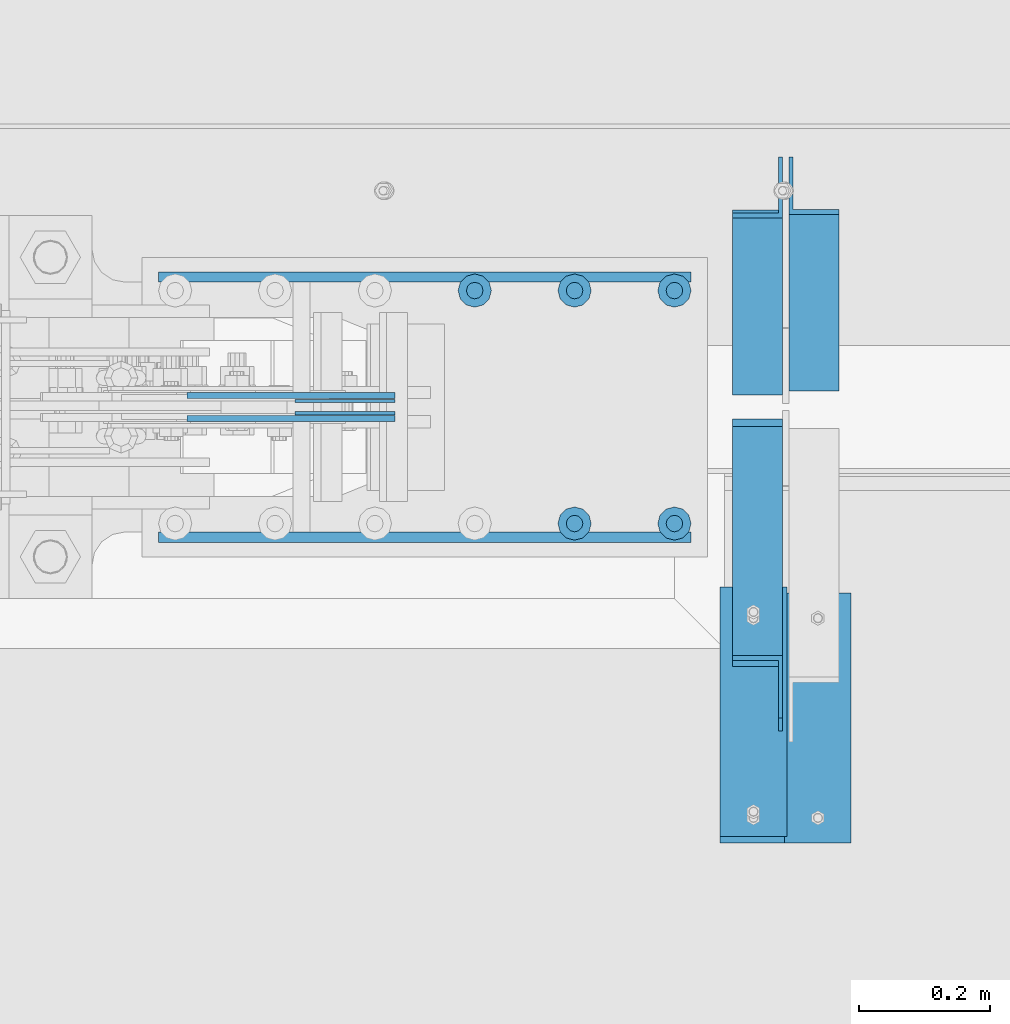
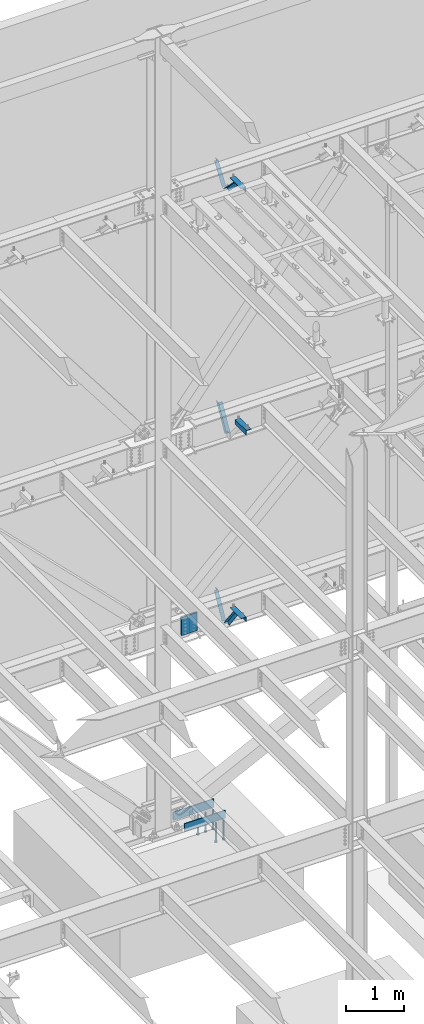
# One storey, part 889 of 1179: 14 beams, 5 members, 14 elements without a shape of their own.
"""IFC2X3 building model written with IfcOpenShell, lengths in millimetres."""

from ifc_helpers import new_model, si_unit, frame, origin_with_axes, place, context, subcontext, project, spatial, faceted_brep, material, type_object, element, aggregate, save


model = new_model("IFC2X3")

# Units and contexts
model_context = context("Model", 3, precision=1e-05, world=origin_with_axes())
body_context = subcontext(model_context, "Body", "Model", "MODEL_VIEW")
ifc_project = project(units=[si_unit("LENGTHUNIT", "METRE", prefix="MILLI"), si_unit("AREAUNIT", "SQUARE_METRE"), si_unit("VOLUMEUNIT", "CUBIC_METRE"), si_unit("MASSUNIT", "GRAM", prefix="KILO"), si_unit("TIMEUNIT", "SECOND"), si_unit("PLANEANGLEUNIT", "RADIAN"), si_unit("SOLIDANGLEUNIT", "STERADIAN"), si_unit("THERMODYNAMICTEMPERATUREUNIT", "DEGREE_CELSIUS"), si_unit("LUMINOUSINTENSITYUNIT", "LUMEN")], contexts=[model_context])

# Site, building, storey
site_placement = place(None, origin_with_axes())
site = spatial("IfcSite", under=ifc_project, at=site_placement, CompositionType="ELEMENT")
building_placement = place(site_placement, origin_with_axes())
building = spatial("IfcBuilding", under=site, at=building_placement, Name="Undefined", CompositionType="ELEMENT")
storey_placement = place(building_placement, origin_with_axes())
storey = spatial("IfcBuildingStorey", under=building, at=storey_placement, Name="Undefined", CompositionType="ELEMENT", Elevation=0.0)

# Assembly, member
assembly_1_placement = place(storey_placement, origin_with_axes())
assembly_1 = element("IfcElementAssembly", 1, at=assembly_1_placement, inside=storey, Name="ANGLE", AssemblyPlace="NOTDEFINED", PredefinedType="RIGID_FRAME")
ifc_material_1 = material(Name="STEEL/A36")
member_type = type_object("IfcMemberType", Name="L3X3X1/4", PredefinedType="NOTDEFINED")
member_1_placement = place(assembly_1_placement, frame((9674.225, 41656.0, 8227.31342088179), z_axis=(0.0, 0.872675718014636, -0.488300206008189), x_axis=(0.0, -0.48830020600819, -0.872675718014636)))
member_1 = element("IfcMember", 2, at=member_1_placement, type_object=member_type, material=ifc_material_1, Name="ANGLE", ObjectType="L3X3X1/4", context=body_context, shape_type="Brep", body=[
    faceted_brep([(266.09845322503, 38.1000000000004, -38.1000000001477), (223.461222774196, 38.1000000000004, 38.0999999997293), (818.212094408347, 38.1000000000004, 38.0999999992346), (818.21209440822, 38.1000000000004, -38.100000000617), (223.461222774196, 31.75, 38.0999999997293), (818.212094408347, 31.75, 38.0999999992346), (262.545350687458, 31.75, -31.7500000001601), (818.212094408227, 31.75, -31.7500000006257), (262.545350687458, -38.1000000000004, -31.7500000001601), (818.212094408227, -38.1000000000004, -31.7500000006257), (266.09845322503, -38.1000000000004, -38.1000000001477), (818.21209440822, -38.1000000000004, -38.100000000617)], [[[0, 1, 2, 3]], [[1, 4, 5, 2]], [[4, 6, 7, 5]], [[6, 8, 9, 7]], [[8, 10, 11, 9]], [[10, 0, 3, 11]], [[5, 7, 9, 11, 3, 2]], [[10, 8, 6, 4, 1, 0]]]),
])
aggregate(assembly_1, [member_1])

assembly_2_placement = place(storey_placement, origin_with_axes())
assembly_2 = element("IfcElementAssembly", 3, at=assembly_2_placement, inside=storey, Name="ANGLE", AssemblyPlace="NOTDEFINED", PredefinedType="RIGID_FRAME")
member_2_placement = place(assembly_2_placement, frame((9588.50025, 41256.8364339201, 3601.33927004389), z_axis=(0.0, 0.873306509536275, -0.487171161299155), x_axis=(0.0, 0.487171161299156, 0.873306509536275)))
member_2 = element("IfcMember", 4, at=member_2_placement, type_object=member_type, material=ifc_material_1, Name="ANGLE", ObjectType="L3X3X1/4", context=body_context, shape_type="Brep", body=[
    faceted_brep([(0.0, 38.0999999999985, -38.0999999999999), (0.0, 38.0999999999985, 38.0999999999999), (594.661720177039, 38.1000000000004, 38.1000000011991), (552.153801037723, 38.1000000000004, -38.0999999989144), (0.0, 31.75, 38.1000000000004), (594.661720177039, 31.75, 38.1000000011991), (0.0, 31.75, -31.75), (555.696127632669, 31.75, -31.7499999988941), (0.0, -38.0999999999985, -31.75), (555.696127632669, -38.1000000000004, -31.7499999988941), (0.0, -38.0999999999985, -38.0999999999999), (552.153801037723, -38.1000000000004, -38.0999999989144)], [[[0, 1, 2, 3]], [[1, 4, 5, 2]], [[4, 6, 7, 5]], [[6, 8, 9, 7]], [[8, 10, 11, 9]], [[10, 0, 3, 11]], [[5, 7, 9, 11, 3, 2]], [[10, 8, 6, 4, 1, 0]]]),
])
aggregate(assembly_2, [member_2])

assembly_3_placement = place(storey_placement, origin_with_axes())
assembly_3 = element("IfcElementAssembly", 5, at=assembly_3_placement, inside=storey, Name="ANGLE", AssemblyPlace="NOTDEFINED", PredefinedType="RIGID_FRAME")
member_3_placement = place(assembly_3_placement, frame((9588.49975000001, 40722.5024246856, 4156.39103856133), z_axis=(0.0, -0.797785167426298, -0.602941810322185), x_axis=(0.0, 0.602941810322187, -0.797785167426297)))
member_3 = element("IfcMember", 6, at=member_3_placement, type_object=member_type, material=ifc_material_1, Name="ANGLE", ObjectType="L3X3X1/4", context=body_context, shape_type="Brep", body=[
    faceted_brep([(110.776215380578, 38.1000000000004, -38.1000000000058), (53.1865686658894, 38.1000000000004, 38.1000000001659), (690.351875241478, 38.1000000000004, 38.1000000007261), (690.351875241598, 38.1000000000004, -38.0999999994892), (53.1865686658894, 31.75, 38.1000000001659), (690.351875241478, 31.75, 38.1000000007261), (105.977078154352, 31.75, -31.7499999999927), (690.351875241595, 31.75, -31.7499999994689), (105.977078154352, -38.1000000000004, -31.7499999999927), (690.351875241595, -38.1000000000004, -31.7499999994689), (110.776215380578, -38.1000000000004, -38.1000000000058), (690.351875241598, -38.1000000000004, -38.0999999994892)], [[[0, 1, 2, 3]], [[1, 4, 5, 2]], [[4, 6, 7, 5]], [[6, 8, 9, 7]], [[8, 10, 11, 9]], [[10, 0, 3, 11]], [[5, 7, 9, 11, 3, 2]], [[10, 8, 6, 4, 1, 0]]]),
])
aggregate(assembly_3, [member_3])

assembly_4_placement = place(storey_placement, origin_with_axes())
assembly_4 = element("IfcElementAssembly", 7, at=assembly_4_placement, inside=storey, Name="ANGLE", AssemblyPlace="NOTDEFINED", PredefinedType="RIGID_FRAME")
member_4_placement = place(assembly_4_placement, frame((9588.50000000001, 40704.7386537875, 13150.1502196524), z_axis=(0.0, -0.706388288025418, -0.707824545025474), x_axis=(0.0, 0.707824545025473, -0.706388288025419)))
member_4 = element("IfcMember", 8, at=member_4_placement, type_object=member_type, material=ifc_material_1, Name="ANGLE", ObjectType="L3X3X1/4", context=body_context, shape_type="Brep", body=[
    faceted_brep([(634.184990526992, 31.75, 38.0999999999767), (634.184990526996, 31.75, -31.7499999999636), (634.184990526996, -38.0999999999985, -31.7499999999636), (634.184990526996, -38.0999999999985, -38.0999999999549), (634.184990526996, 38.0999999999985, -38.0999999999549), (634.184990526992, 38.0999999999985, 38.0999999999767), (113.596638248473, -38.0999999999985, -38.0999999999549), (113.596638248473, 38.0999999999985, -38.0999999999549), (37.2417053522113, 38.0999999999985, 38.0999999999694), (37.2417053522113, 31.75, 38.0999999999694), (107.233727173789, 31.75, -31.7499999999709), (107.233727173789, -38.0999999999985, -31.7499999999709)], [[[0, 1, 2, 3, 4, 5]], [[4, 3, 6, 7]], [[5, 4, 7, 8]], [[0, 5, 8, 9]], [[1, 0, 9, 10]], [[2, 1, 10, 11]], [[3, 2, 11, 6]], [[10, 9, 8, 7, 6, 11]]]),
])
aggregate(assembly_4, [member_4])

assembly_5_placement = place(storey_placement, origin_with_axes())
assembly_5 = element("IfcElementAssembly", 9, at=assembly_5_placement, inside=storey, Name="ANGLE", AssemblyPlace="NOTDEFINED", PredefinedType="RIGID_FRAME")
member_5_placement = place(assembly_5_placement, frame((9588.5, 41248.3636551321, 12707.4244380128), z_axis=(0.0, 0.821716663099518, -0.569896241069015), x_axis=(0.0, 0.569896241069016, 0.821716663099518)))
member_5 = element("IfcMember", 10, at=member_5_placement, type_object=member_type, material=ifc_material_1, Name="ANGLE", ObjectType="L3X3X1/4", context=body_context, shape_type="Brep", body=[
    faceted_brep([(0.0, -38.0999999999985, -38.0999999999999), (0.0, -38.0999999999985, -31.75), (0.0, 31.75, -31.75), (0.0, 31.75, 38.1000000000004), (0.0, 38.0999999999985, 38.0999999999999), (0.0, 38.0999999999985, -38.0999999999999), (527.418547333735, 31.75, 38.0999999993364), (527.418547333735, 38.1000000000004, 38.0999999993364), (474.570533511644, 38.1000000000004, -38.1000000006607), (474.570533511644, -38.1000000000004, -38.1000000006607), (478.974534663488, -38.1000000000004, -31.7500000006621), (478.974534663488, 31.75, -31.7500000006621)], [[[0, 1, 2, 3, 4, 5]], [[4, 3, 6, 7]], [[5, 4, 7, 8]], [[0, 5, 8, 9]], [[1, 0, 9, 10]], [[2, 1, 10, 11]], [[3, 2, 11, 6]], [[10, 9, 8, 7, 6, 11]]]),
])
aggregate(assembly_5, [member_5])

# Assembly, beams
assembly_6_placement = place(storey_placement, origin_with_axes())
assembly_6 = element("IfcElementAssembly", 11, at=assembly_6_placement, inside=storey, Name="BEAM", AssemblyPlace="NOTDEFINED", PredefinedType="RIGID_FRAME")
ifc_material_2 = material(Name="STEEL/A572-GR.50")
beam_type_1 = type_object("IfcBeamType", PredefinedType="NOTDEFINED")
beam_1_placement = place(assembly_6_placement, frame((8882.58952609227, 41189.27475, 3827.46249389647), z_axis=(0.0, 0.0, 1.0), x_axis=(1.0, 0.0, 0.0)))
beam_1 = element("IfcBeam", 12, at=beam_1_placement, type_object=beam_type_1, material=ifc_material_2, Name="PLATE", context=body_context, shape_type="Brep", body=[
    faceted_brep([(0.0, 2.38150000000314, -190.5), (0.0, 2.38150000000314, 190.5), (152.399999999998, 2.38150000000314, 190.5), (152.399999999998, 2.38150000000314, -190.5), (0.0, -2.38150000000314, 190.5), (152.399999999998, -2.38150000000314, 190.5), (0.0, -2.38150000000314, -190.5), (152.399999999998, -2.38150000000314, -190.5)], [[[0, 1, 2, 3]], [[1, 4, 5, 2]], [[4, 6, 7, 5]], [[6, 0, 3, 7]], [[5, 7, 3, 2]], [[6, 4, 1, 0]]]),
])
beam_2_placement = place(assembly_6_placement, frame((8882.58952609227, 41208.32525, 3827.46249389647), z_axis=(0.0, 0.0, 1.0), x_axis=(1.0, 0.0, 0.0)))
beam_2 = element("IfcBeam", 13, at=beam_2_placement, type_object=beam_type_1, material=ifc_material_2, Name="PLATE", context=body_context, shape_type="Brep", body=[
    faceted_brep([(0.0, 2.38150000000314, -190.5), (0.0, 2.38150000000314, 190.5), (152.399999999998, 2.38150000000314, 190.5), (152.399999999998, 2.38150000000314, -190.5), (0.0, -2.38150000000314, 190.5), (152.399999999998, -2.38150000000314, 190.5), (0.0, -2.38150000000314, -190.5), (152.399999999998, -2.38150000000314, -190.5)], [[[0, 1, 2, 3]], [[1, 4, 5, 2]], [[4, 6, 7, 5]], [[6, 0, 3, 7]], [[5, 7, 3, 2]], [[6, 4, 1, 0]]]),
])
aggregate(assembly_6, [beam_1, beam_2])

# Assembly, beam
assembly_7_placement = place(storey_placement, origin_with_axes())
assembly_7 = element("IfcElementAssembly", 14, at=assembly_7_placement, inside=storey, Name="ANGLE", AssemblyPlace="NOTDEFINED", PredefinedType="RIGID_FRAME")
beam_type_2 = type_object("IfcBeamType", Name="L4X4X1/4", PredefinedType="NOTDEFINED")
beam_3_placement = place(assembly_7_placement, frame((9680.575, 40533.6375, 7962.9), z_axis=(1.0, 0.0, 0.0), x_axis=(0.0, 1.0, 0.0)))
beam_3 = element("IfcBeam", 15, at=beam_3_placement, type_object=beam_type_2, material=ifc_material_1, Name="ANGLE", ObjectType="L4X4X1/4", context=body_context, shape_type="Brep", body=[
    faceted_brep([(1.90993887372315e-11, 50.8000000000002, -50.8000000000002), (1.90993887372315e-11, 50.8000000000002, 50.8000000000002), (381.0, 50.8000000000002, 50.7999999999993), (381.0, 50.8000000000002, -50.7999999999993), (0.0, 44.4500000000007, 50.8000000000002), (381.0, 44.4499999999998, 50.7999999999993), (0.0, 44.4500000000007, -44.4499999999998), (381.0, 44.4499999999998, -44.4500000000007), (0.0, -50.7999999999993, -44.4499999999998), (381.0, -50.8000000000002, -44.4500000000007), (-1.81898940354586e-11, -50.7999999999997, -50.8000000000002), (381.0, -50.8000000000002, -50.7999999999993)], [[[0, 1, 2, 3]], [[1, 4, 5, 2]], [[4, 6, 7, 5]], [[6, 8, 9, 7]], [[8, 10, 11, 9]], [[10, 0, 3, 11]], [[5, 7, 9, 11, 3, 2]], [[10, 8, 6, 4, 1, 0]]]),
])
aggregate(assembly_7, [beam_3])

assembly_8_placement = place(storey_placement, origin_with_axes())
assembly_8 = element("IfcElementAssembly", 16, at=assembly_8_placement, inside=storey, Name="ANGLE", AssemblyPlace="NOTDEFINED", PredefinedType="RIGID_FRAME")
beam_4_placement = place(assembly_8_placement, frame((9582.15024999845, 40914.6373750007, 4051.30000000071), z_axis=(-1.0, 0.0, 0.0), x_axis=(0.0, -1.0, 0.0)))
beam_4 = element("IfcBeam", 17, at=beam_4_placement, type_object=beam_type_2, material=ifc_material_1, Name="ANGLE", ObjectType="L4X4X1/4", context=body_context, shape_type="Brep", body=[
    faceted_brep([(1.90993887372315e-11, 50.8000000000002, -50.8000000000002), (1.90993887372315e-11, 50.8000000000002, 50.8000000000002), (381.0, 50.8000000000002, 50.7999999999993), (381.0, 50.8000000000002, -50.7999999999993), (0.0, 44.4500000000007, 50.8000000000002), (381.0, 44.4499999999998, 50.7999999999993), (0.0, 44.4500000000007, -44.4499999999998), (381.0, 44.4499999999998, -44.4500000000007), (0.0, -50.7999999999993, -44.4499999999998), (381.0, -50.8000000000002, -44.4500000000007), (-1.81898940354586e-11, -50.7999999999997, -50.8000000000002), (381.0, -50.8000000000002, -50.7999999999993)], [[[0, 1, 2, 3]], [[1, 4, 5, 2]], [[4, 6, 7, 5]], [[6, 8, 9, 7]], [[8, 10, 11, 9]], [[10, 0, 3, 11]], [[5, 7, 9, 11, 3, 2]], [[10, 8, 6, 4, 1, 0]]]),
])
aggregate(assembly_8, [beam_4])

assembly_9_placement = place(storey_placement, origin_with_axes())
assembly_9 = element("IfcElementAssembly", 18, at=assembly_9_placement, inside=storey, Name="ANGLE", AssemblyPlace="NOTDEFINED", PredefinedType="RIGID_FRAME")
beam_5_placement = place(assembly_9_placement, frame((9582.14999999795, 40924.1624999531, 13068.3), z_axis=(-1.0, 0.0, 0.0), x_axis=(0.0, -1.0, 0.0)))
beam_5 = element("IfcBeam", 19, at=beam_5_placement, type_object=beam_type_2, material=ifc_material_1, Name="ANGLE", ObjectType="L4X4X1/4", context=body_context, shape_type="Brep", body=[
    faceted_brep([(1.90993887372315e-11, 50.8000000000002, -50.8000000000002), (1.90993887372315e-11, 50.8000000000002, 50.8000000000002), (381.0, 50.8000000000002, 50.7999999999993), (381.0, 50.8000000000002, -50.7999999999993), (0.0, 44.4500000000007, 50.8000000000002), (381.0, 44.4499999999998, 50.7999999999993), (0.0, 44.4500000000007, -44.4499999999998), (381.0, 44.4499999999998, -44.4500000000007), (0.0, -50.7999999999993, -44.4499999999998), (381.0, -50.8000000000002, -44.4500000000007), (-1.81898940354586e-11, -50.7999999999997, -50.8000000000002), (381.0, -50.8000000000002, -50.7999999999993)], [[[0, 1, 2, 3]], [[1, 4, 5, 2]], [[4, 6, 7, 5]], [[6, 8, 9, 7]], [[8, 10, 11, 9]], [[10, 0, 3, 11]], [[5, 7, 9, 11, 3, 2]], [[10, 8, 6, 4, 1, 0]]]),
])
aggregate(assembly_9, [beam_5])

assembly_10_placement = place(storey_placement, origin_with_axes())
assembly_10 = element("IfcElementAssembly", 20, at=assembly_10_placement, inside=storey, Name="PLATE", AssemblyPlace="NOTDEFINED", PredefinedType="RIGID_FRAME")
beam_type_3 = type_object("IfcBeamType", PredefinedType="NOTDEFINED")
beam_6_placement = place(assembly_10_placement, frame((9034.98952609227, 41181.3375, 3827.46249389647), z_axis=(0.0, 0.0, -1.0), x_axis=(-1.0, 0.0, 0.0)))
beam_6 = element("IfcBeam", 21, at=beam_6_placement, type_object=beam_type_3, material=ifc_material_2, Name="PLATE", context=body_context, shape_type="Brep", body=[
    faceted_brep([(0.0, 4.76249999999709, -190.5), (0.0, 4.76249999999709, 190.5), (317.499999999995, 4.76250000000073, 190.500000000051), (317.500000000042, 4.76250000000073, -190.499999999973), (0.0, -4.76249999999709, 190.5), (317.499999999995, -4.76250000000073, 190.500000000051), (0.0, -4.76249999999709, -190.5), (317.500000000042, -4.76250000000073, -190.499999999973)], [[[0, 1, 2, 3]], [[1, 4, 5, 2]], [[4, 6, 7, 5]], [[6, 0, 3, 7]], [[5, 7, 3, 2]], [[6, 4, 1, 0]]]),
])
aggregate(assembly_10, [beam_6])

assembly_11_placement = place(storey_placement, origin_with_axes())
assembly_11 = element("IfcElementAssembly", 22, at=assembly_11_placement, inside=storey, Name="PLATE", AssemblyPlace="NOTDEFINED", PredefinedType="RIGID_FRAME")
beam_7_placement = place(assembly_11_placement, frame((8717.48952609227, 41216.2625, 3827.46249389647), z_axis=(0.0, 0.0, -1.0), x_axis=(1.0, 0.0, 0.0)))
beam_7 = element("IfcBeam", 23, at=beam_7_placement, type_object=beam_type_3, material=ifc_material_2, Name="PLATE", context=body_context, shape_type="Brep", body=[
    faceted_brep([(0.0, 4.76249999999709, -190.5), (0.0, 4.76249999999709, 190.5), (317.499999999995, 4.76250000000073, 190.500000000051), (317.500000000042, 4.76250000000073, -190.499999999973), (0.0, -4.76249999999709, 190.5), (317.499999999995, -4.76250000000073, 190.500000000051), (0.0, -4.76249999999709, -190.5), (317.500000000042, -4.76250000000073, -190.499999999973)], [[[0, 1, 2, 3]], [[1, 4, 5, 2]], [[4, 6, 7, 5]], [[6, 0, 3, 7]], [[5, 7, 3, 2]], [[6, 4, 1, 0]]]),
])
aggregate(assembly_11, [beam_7])

assembly_12_placement = place(storey_placement, origin_with_axes())
assembly_12 = element("IfcElementAssembly", 24, at=assembly_12_placement, inside=storey, Name="PLATE", AssemblyPlace="NOTDEFINED", PredefinedType="RIGID_FRAME")
beam_type_4 = type_object("IfcBeamType", PredefinedType="NOTDEFINED")
beam_8_placement = place(assembly_12_placement, frame((8674.1, 41397.2375015263, -266.7), z_axis=(0.0, 0.0, 1.0), x_axis=(1.0, 0.0, 0.0)))
beam_8 = element("IfcBeam", 25, at=beam_8_placement, type_object=beam_type_4, material=ifc_material_2, Name="PLATE", context=body_context, shape_type="Brep", body=[
    faceted_brep([(0.0, -7.9375, -88.9), (0.0, 7.9375, -73.025), (812.799999999999, 7.9375, -73.025), (812.799999999999, -7.9375, -88.9), (0.0, 7.9375, 88.9), (812.799999999999, 7.9375, 88.9), (0.0, -7.9375, 88.9), (812.799999999999, -7.9375, 88.9)], [[[0, 1, 2, 3]], [[4, 5, 2, 1]], [[4, 6, 7, 5]], [[6, 0, 3, 7]], [[5, 7, 3, 2]], [[6, 4, 1, 0]]]),
])
aggregate(assembly_12, [beam_8])

assembly_13_placement = place(storey_placement, origin_with_axes())
assembly_13 = element("IfcElementAssembly", 26, at=assembly_13_placement, inside=storey, Name="PLATE", AssemblyPlace="NOTDEFINED", PredefinedType="RIGID_FRAME")
beam_9_placement = place(assembly_13_placement, frame((8674.1, 41000.3624984737, -266.7), z_axis=(0.0, 0.0, 1.0), x_axis=(1.0, 0.0, 0.0)))
beam_9 = element("IfcBeam", 27, at=beam_9_placement, type_object=beam_type_4, material=ifc_material_2, Name="PLATE", context=body_context, shape_type="Brep", body=[
    faceted_brep([(812.799999999999, 7.9375, -88.9), (812.799999999999, -7.9375, -73.025), (0.0, -7.9375, -73.025), (0.0, 7.9375, -88.9), (0.0, 7.9375, 88.9), (812.799999999999, 7.9375, 88.9), (0.0, -7.9375, 88.9), (812.799999999999, -7.9375, 88.9)], [[[0, 1, 2, 3]], [[3, 4, 5, 0]], [[4, 6, 7, 5]], [[7, 6, 2, 1]], [[5, 7, 1, 0]], [[6, 4, 3, 2]]]),
])
aggregate(assembly_13, [beam_9])

# Assembly, beams
assembly_14_placement = place(storey_placement, origin_with_axes())
assembly_14 = element("IfcElementAssembly", 28, at=assembly_14_placement, inside=storey, Name="EMBED_PLATE", AssemblyPlace="NOTDEFINED", PredefinedType="RIGID_FRAME")
ifc_material_3 = material(Name="STEEL/A108")
beam_type_5 = type_object("IfcBeamType", Name="STUD_1-DIA", PredefinedType="NOTDEFINED")
beam_10_placement = place(assembly_14_placement, frame((9461.5, 41376.6, -393.7), z_axis=(1.0, 0.0, 0.0), x_axis=(0.0, 0.0, -1.0)))
beam_10 = element("IfcBeam", 29, at=beam_10_placement, type_object=beam_type_5, material=ifc_material_3, Name="STUD", ObjectType="STUD_1-DIA", context=body_context, shape_type="Brep", body=[
    faceted_brep([(0.0, -12.7, 0.0), (0.0, -11.0, -6.34999990463257), (382.016, -11.0, -6.34999990463257), (382.016, -12.6999998092651, 0.0), (0.0, -6.34999990463257, -11.0), (382.016, -6.34999990463257, -11.0), (0.0, 0.0, -12.6999998092651), (382.016, 0.0, -12.6999998092651), (0.0, 6.34999990463257, -11.0), (382.016, 6.34999990463257, -11.0), (0.0, 11.0, -6.34999990463257), (382.016, 11.0, -6.34999990463257), (0.0, 12.7, 0.0), (382.016, 12.6999998092651, 0.0), (0.0, 11.0, 6.34999990463257), (382.016, 11.0, 6.34999990463257), (0.0, 6.34999990463257, 11.0), (382.016, 6.34999990463257, 11.0), (0.0, 0.0, 12.6999998092651), (382.016, 0.0, 12.6999998092651), (0.0, -6.34999990463257, 11.0), (382.016, -6.34999990463257, 11.0), (0.0, -11.0, 6.34999990463257), (382.016, -11.0, 6.34999990463257), (386.08, -22.0, -12.6999998092651), (386.08, -25.3999996185303, 0.0), (386.08, -12.6999998092651, -22.0), (386.08, 0.0, -25.3999996185303), (386.08, 12.6999998092651, -22.0), (386.08, 22.0, -12.6999998092651), (386.08, 25.3999996185303, 0.0), (386.08, 22.0, 12.6999998092651), (386.08, 12.6999998092651, 22.0), (386.08, 0.0, 25.3999996185303), (386.08, -12.6999998092651, 22.0), (386.08, -22.0, 12.6999998092651), (406.4, -22.0, -12.6999998092651), (406.4, -25.3999996185303, 0.0), (406.4, -12.6999998092651, -22.0), (406.4, 0.0, -25.3999996185303), (406.4, 12.6999998092651, -22.0), (406.4, 22.0, -12.6999998092651), (406.4, 25.3999996185303, 0.0), (406.4, 22.0, 12.6999998092651), (406.4, 12.6999998092651, 22.0), (406.4, 0.0, 25.3999996185303), (406.4, -12.6999998092651, 22.0), (406.4, -22.0, 12.6999998092651)], [[[0, 1, 2, 3]], [[1, 4, 5, 2]], [[4, 6, 7, 5]], [[6, 8, 9, 7]], [[8, 10, 11, 9]], [[10, 12, 13, 11]], [[12, 14, 15, 13]], [[14, 16, 17, 15]], [[16, 18, 19, 17]], [[18, 20, 21, 19]], [[20, 22, 23, 21]], [[22, 0, 3, 23]], [[22, 20, 18, 16, 14, 12, 10, 8, 6, 4, 1, 0]], [[3, 2, 24, 25]], [[2, 5, 26, 24]], [[5, 7, 27, 26]], [[7, 9, 28, 27]], [[9, 11, 29, 28]], [[11, 13, 30, 29]], [[13, 15, 31, 30]], [[15, 17, 32, 31]], [[17, 19, 33, 32]], [[19, 21, 34, 33]], [[21, 23, 35, 34]], [[23, 3, 25, 35]], [[25, 24, 36, 37]], [[24, 26, 38, 36]], [[26, 27, 39, 38]], [[27, 28, 40, 39]], [[28, 29, 41, 40]], [[29, 30, 42, 41]], [[30, 31, 43, 42]], [[31, 32, 44, 43]], [[32, 33, 45, 44]], [[33, 34, 46, 45]], [[34, 35, 47, 46]], [[35, 25, 37, 47]], [[38, 39, 40, 41, 42, 43, 44, 45, 46, 47, 37, 36]]]),
])
beam_11_placement = place(assembly_14_placement, frame((9309.1, 41376.6, -393.7), z_axis=(1.0, 0.0, 0.0), x_axis=(0.0, 0.0, -1.0)))
beam_11 = element("IfcBeam", 30, at=beam_11_placement, type_object=beam_type_5, material=ifc_material_3, Name="STUD", ObjectType="STUD_1-DIA", context=body_context, shape_type="Brep", body=[
    faceted_brep([(0.0, -12.7, 0.0), (0.0, -11.0, -6.34999990463257), (382.016, -11.0, -6.34999990463257), (382.016, -12.6999998092651, 0.0), (0.0, -6.34999990463257, -11.0), (382.016, -6.34999990463257, -11.0), (0.0, 0.0, -12.6999998092651), (382.016, 0.0, -12.6999998092651), (0.0, 6.34999990463257, -11.0), (382.016, 6.34999990463257, -11.0), (0.0, 11.0, -6.34999990463257), (382.016, 11.0, -6.34999990463257), (0.0, 12.7, 0.0), (382.016, 12.6999998092651, 0.0), (0.0, 11.0, 6.34999990463257), (382.016, 11.0, 6.34999990463257), (0.0, 6.34999990463257, 11.0), (382.016, 6.34999990463257, 11.0), (0.0, 0.0, 12.6999998092651), (382.016, 0.0, 12.6999998092651), (0.0, -6.34999990463257, 11.0), (382.016, -6.34999990463257, 11.0), (0.0, -11.0, 6.34999990463257), (382.016, -11.0, 6.34999990463257), (386.08, -22.0, -12.6999998092651), (386.08, -25.3999996185303, 0.0), (386.08, -12.6999998092651, -22.0), (386.08, 0.0, -25.3999996185303), (386.08, 12.6999998092651, -22.0), (386.08, 22.0, -12.6999998092651), (386.08, 25.3999996185303, 0.0), (386.08, 22.0, 12.6999998092651), (386.08, 12.6999998092651, 22.0), (386.08, 0.0, 25.3999996185303), (386.08, -12.6999998092651, 22.0), (386.08, -22.0, 12.6999998092651), (406.4, -22.0, -12.6999998092651), (406.4, -25.3999996185303, 0.0), (406.4, -12.6999998092651, -22.0), (406.4, 0.0, -25.3999996185303), (406.4, 12.6999998092651, -22.0), (406.4, 22.0, -12.6999998092651), (406.4, 25.3999996185303, 0.0), (406.4, 22.0, 12.6999998092651), (406.4, 12.6999998092651, 22.0), (406.4, 0.0, 25.3999996185303), (406.4, -12.6999998092651, 22.0), (406.4, -22.0, 12.6999998092651)], [[[0, 1, 2, 3]], [[1, 4, 5, 2]], [[4, 6, 7, 5]], [[6, 8, 9, 7]], [[8, 10, 11, 9]], [[10, 12, 13, 11]], [[12, 14, 15, 13]], [[14, 16, 17, 15]], [[16, 18, 19, 17]], [[18, 20, 21, 19]], [[20, 22, 23, 21]], [[22, 0, 3, 23]], [[22, 20, 18, 16, 14, 12, 10, 8, 6, 4, 1, 0]], [[3, 2, 24, 25]], [[2, 5, 26, 24]], [[5, 7, 27, 26]], [[7, 9, 28, 27]], [[9, 11, 29, 28]], [[11, 13, 30, 29]], [[13, 15, 31, 30]], [[15, 17, 32, 31]], [[17, 19, 33, 32]], [[19, 21, 34, 33]], [[21, 23, 35, 34]], [[23, 3, 25, 35]], [[25, 24, 36, 37]], [[24, 26, 38, 36]], [[26, 27, 39, 38]], [[27, 28, 40, 39]], [[28, 29, 41, 40]], [[29, 30, 42, 41]], [[30, 31, 43, 42]], [[31, 32, 44, 43]], [[32, 33, 45, 44]], [[33, 34, 46, 45]], [[34, 35, 47, 46]], [[35, 25, 37, 47]], [[38, 39, 40, 41, 42, 43, 44, 45, 46, 47, 37, 36]]]),
])
beam_12_placement = place(assembly_14_placement, frame((9461.5, 41021.0, -393.7), z_axis=(1.0, 0.0, 0.0), x_axis=(0.0, 0.0, -1.0)))
beam_12 = element("IfcBeam", 31, at=beam_12_placement, type_object=beam_type_5, material=ifc_material_3, Name="STUD", ObjectType="STUD_1-DIA", context=body_context, shape_type="Brep", body=[
    faceted_brep([(0.0, -12.7, 0.0), (0.0, -11.0, -6.34999990463257), (382.016, -11.0, -6.34999990463257), (382.016, -12.6999998092651, 0.0), (0.0, -6.34999990463257, -11.0), (382.016, -6.34999990463257, -11.0), (0.0, 0.0, -12.6999998092651), (382.016, 0.0, -12.6999998092651), (0.0, 6.34999990463257, -11.0), (382.016, 6.34999990463257, -11.0), (0.0, 11.0, -6.34999990463257), (382.016, 11.0, -6.34999990463257), (0.0, 12.7, 0.0), (382.016, 12.6999998092651, 0.0), (0.0, 11.0, 6.34999990463257), (382.016, 11.0, 6.34999990463257), (0.0, 6.34999990463257, 11.0), (382.016, 6.34999990463257, 11.0), (0.0, 0.0, 12.6999998092651), (382.016, 0.0, 12.6999998092651), (0.0, -6.34999990463257, 11.0), (382.016, -6.34999990463257, 11.0), (0.0, -11.0, 6.34999990463257), (382.016, -11.0, 6.34999990463257), (386.08, -22.0, -12.6999998092651), (386.08, -25.3999996185303, 0.0), (386.08, -12.6999998092651, -22.0), (386.08, 0.0, -25.3999996185303), (386.08, 12.6999998092651, -22.0), (386.08, 22.0, -12.6999998092651), (386.08, 25.3999996185303, 0.0), (386.08, 22.0, 12.6999998092651), (386.08, 12.6999998092651, 22.0), (386.08, 0.0, 25.3999996185303), (386.08, -12.6999998092651, 22.0), (386.08, -22.0, 12.6999998092651), (406.4, -22.0, -12.6999998092651), (406.4, -25.3999996185303, 0.0), (406.4, -12.6999998092651, -22.0), (406.4, 0.0, -25.3999996185303), (406.4, 12.6999998092651, -22.0), (406.4, 22.0, -12.6999998092651), (406.4, 25.3999996185303, 0.0), (406.4, 22.0, 12.6999998092651), (406.4, 12.6999998092651, 22.0), (406.4, 0.0, 25.3999996185303), (406.4, -12.6999998092651, 22.0), (406.4, -22.0, 12.6999998092651)], [[[0, 1, 2, 3]], [[1, 4, 5, 2]], [[4, 6, 7, 5]], [[6, 8, 9, 7]], [[8, 10, 11, 9]], [[10, 12, 13, 11]], [[12, 14, 15, 13]], [[14, 16, 17, 15]], [[16, 18, 19, 17]], [[18, 20, 21, 19]], [[20, 22, 23, 21]], [[22, 0, 3, 23]], [[22, 20, 18, 16, 14, 12, 10, 8, 6, 4, 1, 0]], [[3, 2, 24, 25]], [[2, 5, 26, 24]], [[5, 7, 27, 26]], [[7, 9, 28, 27]], [[9, 11, 29, 28]], [[11, 13, 30, 29]], [[13, 15, 31, 30]], [[15, 17, 32, 31]], [[17, 19, 33, 32]], [[19, 21, 34, 33]], [[21, 23, 35, 34]], [[23, 3, 25, 35]], [[25, 24, 36, 37]], [[24, 26, 38, 36]], [[26, 27, 39, 38]], [[27, 28, 40, 39]], [[28, 29, 41, 40]], [[29, 30, 42, 41]], [[30, 31, 43, 42]], [[31, 32, 44, 43]], [[32, 33, 45, 44]], [[33, 34, 46, 45]], [[34, 35, 47, 46]], [[35, 25, 37, 47]], [[38, 39, 40, 41, 42, 43, 44, 45, 46, 47, 37, 36]]]),
])
beam_13_placement = place(assembly_14_placement, frame((9309.1, 41021.0, -393.7), z_axis=(1.0, 0.0, 0.0), x_axis=(0.0, 0.0, -1.0)))
beam_13 = element("IfcBeam", 32, at=beam_13_placement, type_object=beam_type_5, material=ifc_material_3, Name="STUD", ObjectType="STUD_1-DIA", context=body_context, shape_type="Brep", body=[
    faceted_brep([(0.0, -12.7, 0.0), (0.0, -11.0, -6.34999990463257), (382.016, -11.0, -6.34999990463257), (382.016, -12.6999998092651, 0.0), (0.0, -6.34999990463257, -11.0), (382.016, -6.34999990463257, -11.0), (0.0, 0.0, -12.6999998092651), (382.016, 0.0, -12.6999998092651), (0.0, 6.34999990463257, -11.0), (382.016, 6.34999990463257, -11.0), (0.0, 11.0, -6.34999990463257), (382.016, 11.0, -6.34999990463257), (0.0, 12.7, 0.0), (382.016, 12.6999998092651, 0.0), (0.0, 11.0, 6.34999990463257), (382.016, 11.0, 6.34999990463257), (0.0, 6.34999990463257, 11.0), (382.016, 6.34999990463257, 11.0), (0.0, 0.0, 12.6999998092651), (382.016, 0.0, 12.6999998092651), (0.0, -6.34999990463257, 11.0), (382.016, -6.34999990463257, 11.0), (0.0, -11.0, 6.34999990463257), (382.016, -11.0, 6.34999990463257), (386.08, -22.0, -12.6999998092651), (386.08, -25.3999996185303, 0.0), (386.08, -12.6999998092651, -22.0), (386.08, 0.0, -25.3999996185303), (386.08, 12.6999998092651, -22.0), (386.08, 22.0, -12.6999998092651), (386.08, 25.3999996185303, 0.0), (386.08, 22.0, 12.6999998092651), (386.08, 12.6999998092651, 22.0), (386.08, 0.0, 25.3999996185303), (386.08, -12.6999998092651, 22.0), (386.08, -22.0, 12.6999998092651), (406.4, -22.0, -12.6999998092651), (406.4, -25.3999996185303, 0.0), (406.4, -12.6999998092651, -22.0), (406.4, 0.0, -25.3999996185303), (406.4, 12.6999998092651, -22.0), (406.4, 22.0, -12.6999998092651), (406.4, 25.3999996185303, 0.0), (406.4, 22.0, 12.6999998092651), (406.4, 12.6999998092651, 22.0), (406.4, 0.0, 25.3999996185303), (406.4, -12.6999998092651, 22.0), (406.4, -22.0, 12.6999998092651)], [[[0, 1, 2, 3]], [[1, 4, 5, 2]], [[4, 6, 7, 5]], [[6, 8, 9, 7]], [[8, 10, 11, 9]], [[10, 12, 13, 11]], [[12, 14, 15, 13]], [[14, 16, 17, 15]], [[16, 18, 19, 17]], [[18, 20, 21, 19]], [[20, 22, 23, 21]], [[22, 0, 3, 23]], [[22, 20, 18, 16, 14, 12, 10, 8, 6, 4, 1, 0]], [[3, 2, 24, 25]], [[2, 5, 26, 24]], [[5, 7, 27, 26]], [[7, 9, 28, 27]], [[9, 11, 29, 28]], [[11, 13, 30, 29]], [[13, 15, 31, 30]], [[15, 17, 32, 31]], [[17, 19, 33, 32]], [[19, 21, 34, 33]], [[21, 23, 35, 34]], [[23, 3, 25, 35]], [[25, 24, 36, 37]], [[24, 26, 38, 36]], [[26, 27, 39, 38]], [[27, 28, 40, 39]], [[28, 29, 41, 40]], [[29, 30, 42, 41]], [[30, 31, 43, 42]], [[31, 32, 44, 43]], [[32, 33, 45, 44]], [[33, 34, 46, 45]], [[34, 35, 47, 46]], [[35, 25, 37, 47]], [[38, 39, 40, 41, 42, 43, 44, 45, 46, 47, 37, 36]]]),
])
beam_14_placement = place(assembly_14_placement, frame((9156.7, 41376.6, -393.7), z_axis=(1.0, 0.0, 0.0), x_axis=(0.0, 0.0, -1.0)))
beam_14 = element("IfcBeam", 33, at=beam_14_placement, type_object=beam_type_5, material=ifc_material_3, Name="STUD", ObjectType="STUD_1-DIA", context=body_context, shape_type="Brep", body=[
    faceted_brep([(0.0, -12.7, 0.0), (0.0, -11.0, -6.34999990463257), (382.016, -11.0, -6.34999990463257), (382.016, -12.6999998092651, 0.0), (0.0, -6.34999990463257, -11.0), (382.016, -6.34999990463257, -11.0), (0.0, 0.0, -12.6999998092651), (382.016, 0.0, -12.6999998092651), (0.0, 6.34999990463257, -11.0), (382.016, 6.34999990463257, -11.0), (0.0, 11.0, -6.34999990463257), (382.016, 11.0, -6.34999990463257), (0.0, 12.7, 0.0), (382.016, 12.6999998092651, 0.0), (0.0, 11.0, 6.34999990463257), (382.016, 11.0, 6.34999990463257), (0.0, 6.34999990463257, 11.0), (382.016, 6.34999990463257, 11.0), (0.0, 0.0, 12.6999998092651), (382.016, 0.0, 12.6999998092651), (0.0, -6.34999990463257, 11.0), (382.016, -6.34999990463257, 11.0), (0.0, -11.0, 6.34999990463257), (382.016, -11.0, 6.34999990463257), (386.08, -22.0, -12.6999998092651), (386.08, -25.3999996185303, 0.0), (386.08, -12.6999998092651, -22.0), (386.08, 0.0, -25.3999996185303), (386.08, 12.6999998092651, -22.0), (386.08, 22.0, -12.6999998092651), (386.08, 25.3999996185303, 0.0), (386.08, 22.0, 12.6999998092651), (386.08, 12.6999998092651, 22.0), (386.08, 0.0, 25.3999996185303), (386.08, -12.6999998092651, 22.0), (386.08, -22.0, 12.6999998092651), (406.4, -22.0, -12.6999998092651), (406.4, -25.3999996185303, 0.0), (406.4, -12.6999998092651, -22.0), (406.4, 0.0, -25.3999996185303), (406.4, 12.6999998092651, -22.0), (406.4, 22.0, -12.6999998092651), (406.4, 25.3999996185303, 0.0), (406.4, 22.0, 12.6999998092651), (406.4, 12.6999998092651, 22.0), (406.4, 0.0, 25.3999996185303), (406.4, -12.6999998092651, 22.0), (406.4, -22.0, 12.6999998092651)], [[[0, 1, 2, 3]], [[1, 4, 5, 2]], [[4, 6, 7, 5]], [[6, 8, 9, 7]], [[8, 10, 11, 9]], [[10, 12, 13, 11]], [[12, 14, 15, 13]], [[14, 16, 17, 15]], [[16, 18, 19, 17]], [[18, 20, 21, 19]], [[20, 22, 23, 21]], [[22, 0, 3, 23]], [[22, 20, 18, 16, 14, 12, 10, 8, 6, 4, 1, 0]], [[3, 2, 24, 25]], [[2, 5, 26, 24]], [[5, 7, 27, 26]], [[7, 9, 28, 27]], [[9, 11, 29, 28]], [[11, 13, 30, 29]], [[13, 15, 31, 30]], [[15, 17, 32, 31]], [[17, 19, 33, 32]], [[19, 21, 34, 33]], [[21, 23, 35, 34]], [[23, 3, 25, 35]], [[25, 24, 36, 37]], [[24, 26, 38, 36]], [[26, 27, 39, 38]], [[27, 28, 40, 39]], [[28, 29, 41, 40]], [[29, 30, 42, 41]], [[30, 31, 43, 42]], [[31, 32, 44, 43]], [[32, 33, 45, 44]], [[33, 34, 46, 45]], [[34, 35, 47, 46]], [[35, 25, 37, 47]], [[38, 39, 40, 41, 42, 43, 44, 45, 46, 47, 37, 36]]]),
])
aggregate(assembly_14, [beam_10, beam_11, beam_12, beam_13, beam_14])

save(model, "model.ifc")
